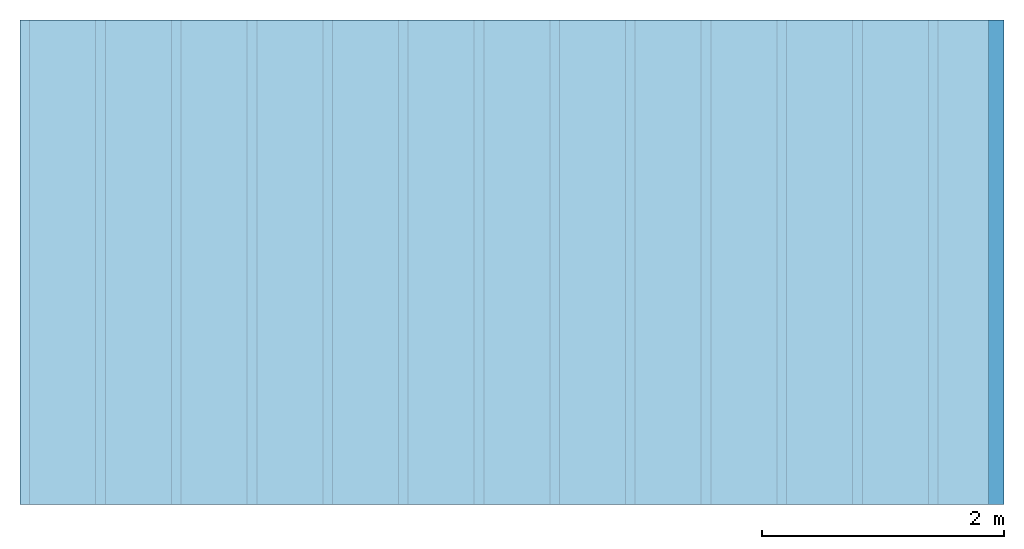
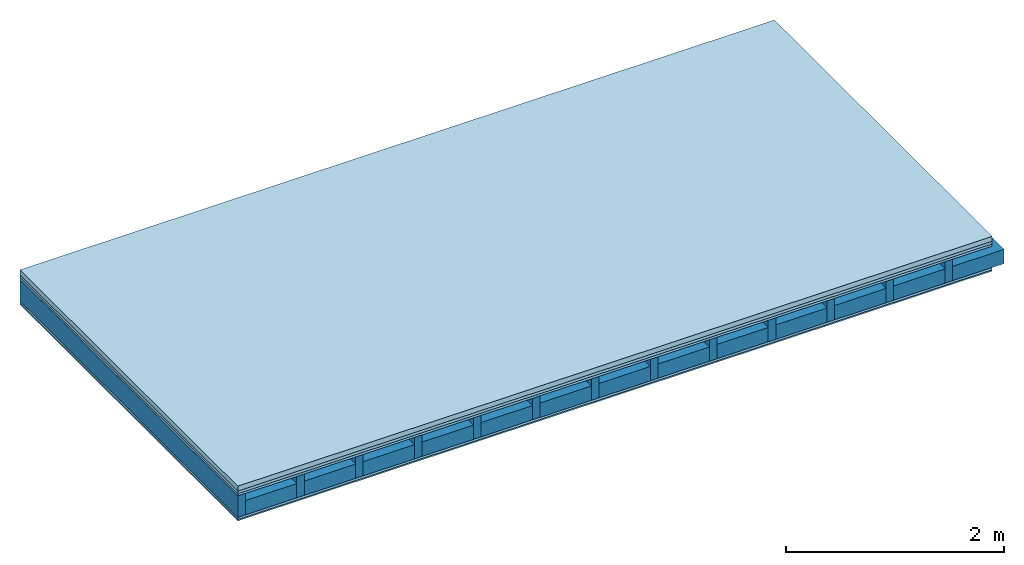
# One storey: 5 plates, 2 members, 1 element without a shape of its own.
"""IFC4 building model written with IfcOpenShell, lengths in metres."""

from ifc_helpers import new_model, si_unit, derived_unit, direction, frame, frame_2d, origin, origin_with_axes, place, context, project, spatial, rectangle, extrude, material, layer, layer_set, type_object, element, aggregate, save


model = new_model("IFC4")

# Units and contexts
plan_context = context("Plan", 3, precision=1e-05, world=origin(), true_north=direction((0.0, 1.0)))
model_context = context("Model", 3, precision=1e-05, world=origin(), true_north=direction((0.0, 1.0)))
ifc_project = project(units=[si_unit("LENGTHUNIT", "METRE"), derived_unit("SOUNDPRESSUREUNIT", [(si_unit("PRESSUREUNIT", "PASCAL", prefix="MICRO"), 0)]), si_unit("ENERGYUNIT", "JOULE", prefix="MEGA"), si_unit("MASSUNIT", "GRAM", prefix="KILO"), derived_unit("THERMALTRANSMITTANCEUNIT", [(si_unit("POWERUNIT", "WATT"), 1), (si_unit("AREAUNIT", "SQUARE_METRE"), -1), (si_unit("THERMODYNAMICTEMPERATUREUNIT", "KELVIN"), -1)]), derived_unit("AREADENSITYUNIT", [(si_unit("MASSUNIT", "GRAM", prefix="KILO"), 1), (si_unit("AREAUNIT", "SQUARE_METRE"), -1)]), derived_unit("USERDEFINED", [(si_unit("ENERGYUNIT", "JOULE", prefix="MEGA"), 1), (si_unit("AREAUNIT", "SQUARE_METRE"), -1)])], contexts=[plan_context, model_context])

# Site, building, storey
site = spatial("IfcSite", under=ifc_project)
building_placement = place(None, origin())
building = spatial("IfcBuilding", under=site, at=building_placement)
storey_placement = place(building_placement, origin())
storey = spatial("IfcBuildingStorey", under=building, at=storey_placement)

# Slab, members, plates
ifc_material_1 = material(Category="04.005")
ifc_layer_1 = layer(ifc_material_1, 0.055, Name="On-material")
ifc_material_2 = material()
ifc_layer_2 = layer(ifc_material_2, 0.03, Name="Impact sound insulation")
ifc_material_3 = material(Category="07.001")
ifc_layer_3 = layer(ifc_material_3, 0.025, Name="Sub-floor")
ifc_material_4 = material(Name="Rigid, of the art")
ifc_layer_4 = layer(ifc_material_4, 0.0, Name="Bond")
ifc_layer_5 = layer(None, 0.24, Name="Supporting structure")
ifc_layer_6 = layer(ifc_material_4, 0.0, Name="Bond")
ifc_layer_7 = layer(ifc_material_3, 0.025, Name="Lower layer 1")
ifc_material_5 = material(Category="03.007")
ifc_layer_8 = layer(ifc_material_5, 0.015, Name="Lower 2nd layer")
ifc_layer_set = layer_set([ifc_layer_1, ifc_layer_2, ifc_layer_3, ifc_layer_4, ifc_layer_5, ifc_layer_6, ifc_layer_7, ifc_layer_8])
slab_type = type_object("IfcSlabType", Name="A0300", PredefinedType="NOTDEFINED", material=ifc_layer_set)
slab_placement = place(None, frame((0.0, 0.0, 0.0), z_axis=(0.0, 0.0, -1.0), x_axis=(1.0, 0.0, 0.0)))
slab = element("IfcSlab", 1, at=slab_placement, inside=storey, type_object=slab_type, material=ifc_layer_set, Name="Slab #1")
ifc_material_6 = material()
member_1_placement = place(slab_placement, origin())
member_1 = element("IfcMember", 2, at=member_1_placement, material=ifc_material_6, Name="Supporting structure", context=plan_context, shape_type="SweptSolid", body=[
    extrude(rectangle(XDim=0.08, YDim=0.24, at=frame_2d((0.04, 0.12), x_axis=(1.0, 0.0))), frame((0.0, 4.0, 0.11), z_axis=(0.0, -1.0, 0.0), x_axis=(1.0, 0.0, 0.0)), (0.0, 0.0, 1.0), 4.0),
    extrude(rectangle(XDim=0.08, YDim=0.24, at=frame_2d((0.04, 0.12), x_axis=(1.0, 0.0))), frame((0.625, 4.0, 0.11), z_axis=(0.0, -1.0, 0.0), x_axis=(1.0, 0.0, 0.0)), (0.0, 0.0, 1.0), 4.0),
    extrude(rectangle(XDim=0.08, YDim=0.24, at=frame_2d((0.04, 0.12), x_axis=(1.0, 0.0))), frame((1.25, 4.0, 0.11), z_axis=(0.0, -1.0, 0.0), x_axis=(1.0, 0.0, 0.0)), (0.0, 0.0, 1.0), 4.0),
    extrude(rectangle(XDim=0.08, YDim=0.24, at=frame_2d((0.04, 0.12), x_axis=(1.0, 0.0))), frame((1.875, 4.0, 0.11), z_axis=(0.0, -1.0, 0.0), x_axis=(1.0, 0.0, 0.0)), (0.0, 0.0, 1.0), 4.0),
    extrude(rectangle(XDim=0.08, YDim=0.24, at=frame_2d((0.04, 0.12), x_axis=(1.0, 0.0))), frame((2.5, 4.0, 0.11), z_axis=(0.0, -1.0, 0.0), x_axis=(1.0, 0.0, 0.0)), (0.0, 0.0, 1.0), 4.0),
    extrude(rectangle(XDim=0.08, YDim=0.24, at=frame_2d((0.04, 0.12), x_axis=(1.0, 0.0))), frame((3.125, 4.0, 0.11), z_axis=(0.0, -1.0, 0.0), x_axis=(1.0, 0.0, 0.0)), (0.0, 0.0, 1.0), 4.0),
    extrude(rectangle(XDim=0.08, YDim=0.24, at=frame_2d((0.04, 0.12), x_axis=(1.0, 0.0))), frame((3.75, 4.0, 0.11), z_axis=(0.0, -1.0, 0.0), x_axis=(1.0, 0.0, 0.0)), (0.0, 0.0, 1.0), 4.0),
    extrude(rectangle(XDim=0.08, YDim=0.24, at=frame_2d((0.04, 0.12), x_axis=(1.0, 0.0))), frame((4.375, 4.0, 0.11), z_axis=(0.0, -1.0, 0.0), x_axis=(1.0, 0.0, 0.0)), (0.0, 0.0, 1.0), 4.0),
    extrude(rectangle(XDim=0.08, YDim=0.24, at=frame_2d((0.04, 0.12), x_axis=(1.0, 0.0))), frame((5.0, 4.0, 0.11), z_axis=(0.0, -1.0, 0.0), x_axis=(1.0, 0.0, 0.0)), (0.0, 0.0, 1.0), 4.0),
    extrude(rectangle(XDim=0.08, YDim=0.24, at=frame_2d((0.04, 0.12), x_axis=(1.0, 0.0))), frame((5.625, 4.0, 0.11), z_axis=(0.0, -1.0, 0.0), x_axis=(1.0, 0.0, 0.0)), (0.0, 0.0, 1.0), 4.0),
    extrude(rectangle(XDim=0.08, YDim=0.24, at=frame_2d((0.04, 0.12), x_axis=(1.0, 0.0))), frame((6.25, 4.0, 0.11), z_axis=(0.0, -1.0, 0.0), x_axis=(1.0, 0.0, 0.0)), (0.0, 0.0, 1.0), 4.0),
    extrude(rectangle(XDim=0.08, YDim=0.24, at=frame_2d((0.04, 0.12), x_axis=(1.0, 0.0))), frame((6.875, 4.0, 0.11), z_axis=(0.0, -1.0, 0.0), x_axis=(1.0, 0.0, 0.0)), (0.0, 0.0, 1.0), 4.0),
    extrude(rectangle(XDim=0.08, YDim=0.24, at=frame_2d((0.04, 0.12), x_axis=(1.0, 0.0))), frame((7.5, 4.0, 0.11), z_axis=(0.0, -1.0, 0.0), x_axis=(1.0, 0.0, 0.0)), (0.0, 0.0, 1.0), 4.0),
])
ifc_material_7 = material()
member_2_placement = place(slab_placement, origin())
member_2 = element("IfcMember", 3, at=member_2_placement, material=ifc_material_7, Name="Cavity", context=plan_context, shape_type="SweptSolid", body=[
    extrude(rectangle(XDim=0.545, YDim=0.16, at=frame_2d((0.2725, 0.08), x_axis=(1.0, 0.0))), frame((0.08, 4.0, 0.19), z_axis=(0.0, -1.0, 0.0), x_axis=(1.0, 0.0, 0.0)), (0.0, 0.0, 1.0), 4.0),
    extrude(rectangle(XDim=0.545, YDim=0.16, at=frame_2d((0.2725, 0.08), x_axis=(1.0, 0.0))), frame((0.705, 4.0, 0.19), z_axis=(0.0, -1.0, 0.0), x_axis=(1.0, 0.0, 0.0)), (0.0, 0.0, 1.0), 4.0),
    extrude(rectangle(XDim=0.545, YDim=0.16, at=frame_2d((0.2725, 0.08), x_axis=(1.0, 0.0))), frame((1.33, 4.0, 0.19), z_axis=(0.0, -1.0, 0.0), x_axis=(1.0, 0.0, 0.0)), (0.0, 0.0, 1.0), 4.0),
    extrude(rectangle(XDim=0.545, YDim=0.16, at=frame_2d((0.2725, 0.08), x_axis=(1.0, 0.0))), frame((1.955, 4.0, 0.19), z_axis=(0.0, -1.0, 0.0), x_axis=(1.0, 0.0, 0.0)), (0.0, 0.0, 1.0), 4.0),
    extrude(rectangle(XDim=0.545, YDim=0.16, at=frame_2d((0.2725, 0.08), x_axis=(1.0, 0.0))), frame((2.58, 4.0, 0.19), z_axis=(0.0, -1.0, 0.0), x_axis=(1.0, 0.0, 0.0)), (0.0, 0.0, 1.0), 4.0),
    extrude(rectangle(XDim=0.545, YDim=0.16, at=frame_2d((0.2725, 0.08), x_axis=(1.0, 0.0))), frame((3.205, 4.0, 0.19), z_axis=(0.0, -1.0, 0.0), x_axis=(1.0, 0.0, 0.0)), (0.0, 0.0, 1.0), 4.0),
    extrude(rectangle(XDim=0.545, YDim=0.16, at=frame_2d((0.2725, 0.08), x_axis=(1.0, 0.0))), frame((3.83, 4.0, 0.19), z_axis=(0.0, -1.0, 0.0), x_axis=(1.0, 0.0, 0.0)), (0.0, 0.0, 1.0), 4.0),
    extrude(rectangle(XDim=0.545, YDim=0.16, at=frame_2d((0.2725, 0.08), x_axis=(1.0, 0.0))), frame((4.455, 4.0, 0.19), z_axis=(0.0, -1.0, 0.0), x_axis=(1.0, 0.0, 0.0)), (0.0, 0.0, 1.0), 4.0),
    extrude(rectangle(XDim=0.545, YDim=0.16, at=frame_2d((0.2725, 0.08), x_axis=(1.0, 0.0))), frame((5.08, 4.0, 0.19), z_axis=(0.0, -1.0, 0.0), x_axis=(1.0, 0.0, 0.0)), (0.0, 0.0, 1.0), 4.0),
    extrude(rectangle(XDim=0.545, YDim=0.16, at=frame_2d((0.2725, 0.08), x_axis=(1.0, 0.0))), frame((5.705, 4.0, 0.19), z_axis=(0.0, -1.0, 0.0), x_axis=(1.0, 0.0, 0.0)), (0.0, 0.0, 1.0), 4.0),
    extrude(rectangle(XDim=0.545, YDim=0.16, at=frame_2d((0.2725, 0.08), x_axis=(1.0, 0.0))), frame((6.33, 4.0, 0.19), z_axis=(0.0, -1.0, 0.0), x_axis=(1.0, 0.0, 0.0)), (0.0, 0.0, 1.0), 4.0),
    extrude(rectangle(XDim=0.545, YDim=0.16, at=frame_2d((0.2725, 0.08), x_axis=(1.0, 0.0))), frame((6.955, 4.0, 0.19), z_axis=(0.0, -1.0, 0.0), x_axis=(1.0, 0.0, 0.0)), (0.0, 0.0, 1.0), 4.0),
    extrude(rectangle(XDim=0.545, YDim=0.16, at=frame_2d((0.2725, 0.08), x_axis=(1.0, 0.0))), frame((7.58, 4.0, 0.19), z_axis=(0.0, -1.0, 0.0), x_axis=(1.0, 0.0, 0.0)), (0.0, 0.0, 1.0), 4.0),
])
plate_1_placement = place(slab_placement, origin())
plate_1 = element("IfcPlate", 4, at=plate_1_placement, material=ifc_material_1, Name="On-material", context=plan_context, shape_type="SweptSolid", body=[
    extrude(rectangle(XDim=8.0, YDim=4.0, at=frame_2d((4.0, 2.0), x_axis=(1.0, 0.0))), origin_with_axes(), (0.0, 0.0, 1.0), 0.055),
])
plate_2_placement = place(slab_placement, origin())
plate_2 = element("IfcPlate", 5, at=plate_2_placement, material=ifc_material_2, Name="Impact sound insulation", context=plan_context, shape_type="SweptSolid", body=[
    extrude(rectangle(XDim=8.0, YDim=4.0, at=frame_2d((4.0, 2.0), x_axis=(1.0, 0.0))), frame((0.0, 0.0, 0.055), z_axis=(0.0, 0.0, 1.0), x_axis=(1.0, 0.0, 0.0)), (0.0, 0.0, 1.0), 0.03),
])
plate_3_placement = place(slab_placement, origin())
plate_3 = element("IfcPlate", 6, at=plate_3_placement, material=ifc_material_3, Name="Sub-floor", context=plan_context, shape_type="SweptSolid", body=[
    extrude(rectangle(XDim=8.0, YDim=4.0, at=frame_2d((4.0, 2.0), x_axis=(1.0, 0.0))), frame((0.0, 0.0, 0.085), z_axis=(0.0, 0.0, 1.0), x_axis=(1.0, 0.0, 0.0)), (0.0, 0.0, 1.0), 0.025),
])
plate_4_placement = place(slab_placement, origin())
plate_4 = element("IfcPlate", 7, at=plate_4_placement, material=ifc_material_3, Name="Lower layer 1", context=plan_context, shape_type="SweptSolid", body=[
    extrude(rectangle(XDim=8.0, YDim=4.0, at=frame_2d((4.0, 2.0), x_axis=(1.0, 0.0))), frame((0.0, 0.0, 0.35), z_axis=(0.0, 0.0, 1.0), x_axis=(1.0, 0.0, 0.0)), (0.0, 0.0, 1.0), 0.025),
])
plate_5_placement = place(slab_placement, origin())
plate_5 = element("IfcPlate", 8, at=plate_5_placement, material=ifc_material_5, Name="Lower 2nd layer", context=plan_context, shape_type="SweptSolid", body=[
    extrude(rectangle(XDim=8.0, YDim=4.0, at=frame_2d((4.0, 2.0), x_axis=(1.0, 0.0))), frame((0.0, 0.0, 0.375), z_axis=(0.0, 0.0, 1.0), x_axis=(1.0, 0.0, 0.0)), (0.0, 0.0, 1.0), 0.015),
])
aggregate(slab, [plate_1, plate_2, plate_3, member_1, member_2, plate_4, plate_5])

save(model, "model.ifc")
